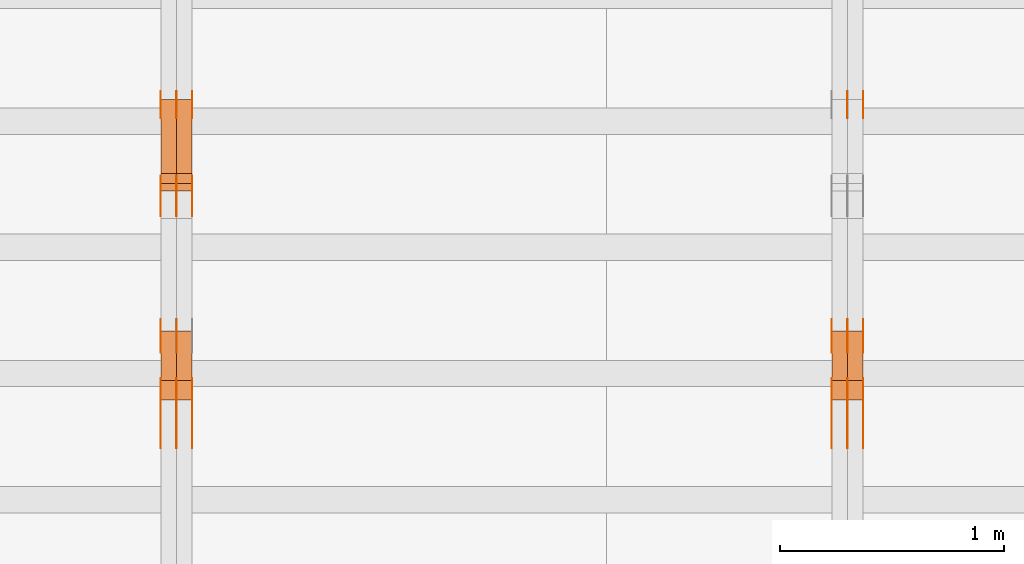
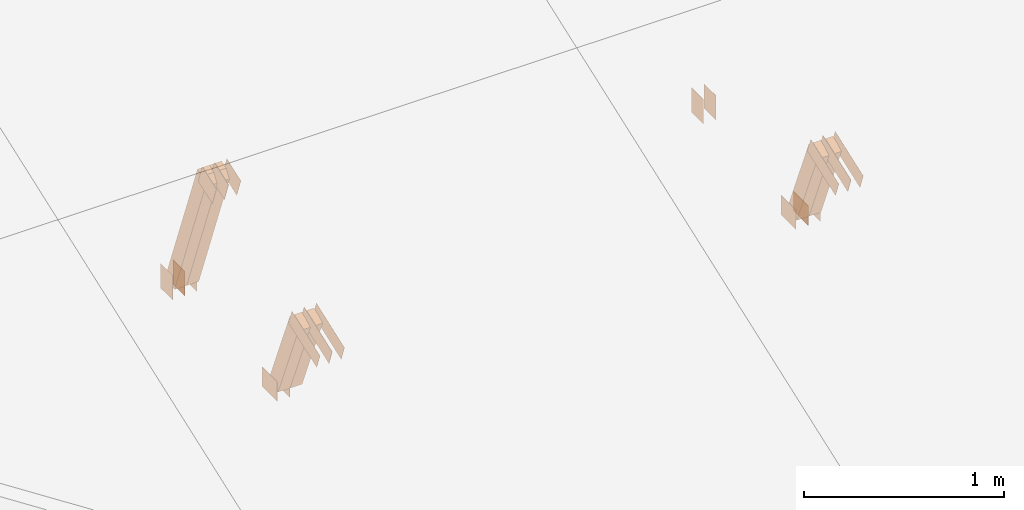
# One storey, part 140 of 189: 30 proxies.
"""IFC2X3 building model written with IfcOpenShell, lengths in millimetres."""

from ifc_helpers import new_model, entity, si_unit, converted_unit, derived_unit, direction, frame, frame_2d, origin, origin_2d_with_axis, place, context, subcontext, project, spatial, polyline, rectangle, outline, extrude, source, transform, mapped, material, type_object, type_shapes, element, save


model = new_model("IFC2X3")

# Units and contexts
model_context = context("Model", 3, precision=0.01, world=origin(), true_north=direction((6.12303176911189e-17, 1.0)))
body_context = subcontext(model_context, "Body", "Model", "MODEL_VIEW")
ifc_project = project(units=[si_unit("LENGTHUNIT", "METRE", prefix="MILLI"), si_unit("AREAUNIT", "SQUARE_METRE"), si_unit("VOLUMEUNIT", "CUBIC_METRE"), converted_unit("PLANEANGLEUNIT", "DEGREE", entity("IfcRatioMeasure", 0.0174532925199433), si_unit("PLANEANGLEUNIT", "RADIAN"), dimensions=[0, 0, 0, 0, 0, 0, 0]), si_unit("MASSUNIT", "GRAM", prefix="KILO"), derived_unit("MASSDENSITYUNIT", [(si_unit("MASSUNIT", "GRAM", prefix="KILO"), 1), (si_unit("LENGTHUNIT", "METRE"), -3)]), si_unit("TIMEUNIT", "SECOND"), si_unit("FREQUENCYUNIT", "HERTZ"), si_unit("THERMODYNAMICTEMPERATUREUNIT", "DEGREE_CELSIUS"), derived_unit("THERMALTRANSMITTANCEUNIT", [(si_unit("MASSUNIT", "GRAM", prefix="KILO"), 1), (si_unit("THERMODYNAMICTEMPERATUREUNIT", "KELVIN"), -1), (si_unit("TIMEUNIT", "SECOND"), -3)]), derived_unit("VOLUMETRICFLOWRATEUNIT", [(si_unit("LENGTHUNIT", "METRE"), 3), (si_unit("TIMEUNIT", "SECOND"), -1)]), si_unit("ELECTRICCURRENTUNIT", "AMPERE"), si_unit("ELECTRICVOLTAGEUNIT", "VOLT"), si_unit("POWERUNIT", "WATT"), si_unit("FORCEUNIT", "NEWTON"), si_unit("ILLUMINANCEUNIT", "LUX"), si_unit("LUMINOUSFLUXUNIT", "LUMEN"), si_unit("LUMINOUSINTENSITYUNIT", "CANDELA"), derived_unit("USERDEFINED", [(si_unit("MASSUNIT", "GRAM", prefix="KILO"), -1), (si_unit("LENGTHUNIT", "METRE"), -2), (si_unit("TIMEUNIT", "SECOND"), 3), (si_unit("LUMINOUSFLUXUNIT", "LUMEN"), 1)]), derived_unit("LINEARVELOCITYUNIT", [(si_unit("LENGTHUNIT", "METRE"), 1), (si_unit("TIMEUNIT", "SECOND"), -1)]), si_unit("PRESSUREUNIT", "PASCAL"), derived_unit("USERDEFINED", [(si_unit("LENGTHUNIT", "METRE"), -2), (si_unit("MASSUNIT", "GRAM", prefix="KILO"), 1), (si_unit("TIMEUNIT", "SECOND"), -2)])], contexts=[model_context])

# Site, building, storey
site_placement = place(None, origin())
site = spatial("IfcSite", under=ifc_project, at=site_placement, CompositionType="ELEMENT")
building_placement = place(site_placement, origin())
building = spatial("IfcBuilding", under=site, at=building_placement, CompositionType="ELEMENT")
storey_placement = place(building_placement, origin())
storey = spatial("IfcBuildingStorey", under=building, at=storey_placement, Name="Default", CompositionType="ELEMENT", Elevation=0.0)

# Proxies
ifc_material_1 = material(Name="IfcSurfaceStyle #231430")
building_element_proxy_type_1 = type_object("IfcBuildingElementProxyType", PredefinedType="NOTDEFINED", material=ifc_material_1)
shared_shape_1 = source(origin(), body_context, "Body", "SweptSolid", [
    extrude(rectangle(XDim=150.0, YDim=120.0, at=frame_2d((1.4210854715202e-14, -7.105427357601e-15), x_axis=(1.0, 0.0))), frame((75.0, 60.0004961323721, 0.0), z_axis=(0.0, 0.0, 1.0), x_axis=(-1.0, 0.0, 0.0)), (0.0, 0.0, 1.0), 1.3),
])
type_shapes(building_element_proxy_type_1, [shared_shape_1])
proxy_1_placement = place(building_placement, frame((42301.3, 2940.99169136763, 170.0), z_axis=(-1.0, 0.0, 0.0), x_axis=(0.0, 0.0, 1.0)))
element("IfcBuildingElementProxy", 1, at=proxy_1_placement, inside=storey, type_object=building_element_proxy_type_1, material=ifc_material_1, context=body_context, shape_type="MappedRepresentation", body=[
    mapped(shared_shape_1, transform((0.0, 0.0, 0.0), scale=1.0)),
])
ifc_material_2 = material(Name="IfcSurfaceStyle #231373")
building_element_proxy_type_2 = type_object("IfcBuildingElementProxyType", PredefinedType="NOTDEFINED", material=ifc_material_2)
shared_shape_2 = source(origin(), body_context, "Body", "SweptSolid", [
    extrude(rectangle(XDim=150.0, YDim=120.0, at=frame_2d((1.4210854715202e-14, -7.105427357601e-15), x_axis=(1.0, 0.0))), frame((75.0, 60.0004961323721, 0.0), z_axis=(0.0, 0.0, 1.0), x_axis=(-1.0, 0.0, 0.0)), (0.0, 0.0, 1.0), 1.29999999999999),
])
type_shapes(building_element_proxy_type_2, [shared_shape_2])
proxy_2_placement = place(building_placement, frame((42230.0, 2940.99169136763, 170.0), z_axis=(-1.0, 0.0, 0.0), x_axis=(0.0, 0.0, 1.0)))
element("IfcBuildingElementProxy", 2, at=proxy_2_placement, inside=storey, type_object=building_element_proxy_type_2, material=ifc_material_2, context=body_context, shape_type="MappedRepresentation", body=[
    mapped(shared_shape_2, transform((0.0, 0.0, 0.0), scale=1.0)),
])
ifc_material_3 = material(Name="IfcSurfaceStyle #230518")
building_element_proxy_type_3 = type_object("IfcBuildingElementProxyType", PredefinedType="NOTDEFINED", material=ifc_material_3)
shared_shape_3 = source(origin(), body_context, "Body", "SweptSolid", [
    extrude(rectangle(XDim=150.0, YDim=120.0, at=origin_2d_with_axis()), frame((75.0004757715869, 60.0, 0.0), z_axis=(0.0, 0.0, 1.0), x_axis=(-1.0, 0.0, 0.0)), (0.0, 0.0, 1.0), 1.3),
])
type_shapes(building_element_proxy_type_3, [shared_shape_3])
proxy_3_placement = place(building_placement, frame((42301.3, 1892.68702422841, 305.0), z_axis=(-1.0, 0.0, 0.0), x_axis=(0.0, 1.0, 0.0)))
element("IfcBuildingElementProxy", 3, at=proxy_3_placement, inside=storey, type_object=building_element_proxy_type_3, material=ifc_material_3, context=body_context, shape_type="MappedRepresentation", body=[
    mapped(shared_shape_3, transform((0.0, 0.0, 0.0), scale=1.0)),
])
ifc_material_4 = material(Name="IfcSurfaceStyle #230461")
building_element_proxy_type_4 = type_object("IfcBuildingElementProxyType", PredefinedType="NOTDEFINED", material=ifc_material_4)
shared_shape_4 = source(origin(), body_context, "Body", "SweptSolid", [
    extrude(rectangle(XDim=150.0, YDim=120.0, at=origin_2d_with_axis()), frame((75.0004757715869, 60.0, 0.0), z_axis=(0.0, 0.0, 1.0), x_axis=(-1.0, 0.0, 0.0)), (0.0, 0.0, 1.0), 1.29999999999999),
])
type_shapes(building_element_proxy_type_4, [shared_shape_4])
proxy_4_placement = place(building_placement, frame((42230.0, 1892.68702422841, 305.0), z_axis=(-1.0, 0.0, 0.0), x_axis=(0.0, 1.0, 0.0)))
element("IfcBuildingElementProxy", 4, at=proxy_4_placement, inside=storey, type_object=building_element_proxy_type_4, material=ifc_material_4, context=body_context, shape_type="MappedRepresentation", body=[
    mapped(shared_shape_4, transform((0.0, 0.0, 0.0), scale=1.0)),
])
ifc_material_5 = material(Name="IfcSurfaceStyle #230404")
building_element_proxy_type_5 = type_object("IfcBuildingElementProxyType", PredefinedType="NOTDEFINED", material=ifc_material_5)
shared_shape_5 = source(origin(), body_context, "Body", "SweptSolid", [
    extrude(rectangle(XDim=150.0, YDim=120.0, at=origin_2d_with_axis()), frame((75.0004757715869, 60.0, 0.0), z_axis=(0.0, 0.0, 1.0), x_axis=(-1.0, 0.0, 0.0)), (0.0, 0.0, 1.0), 1.29999999999999),
])
type_shapes(building_element_proxy_type_5, [shared_shape_5])
proxy_5_placement = place(building_placement, frame((42231.3, 1892.68702422841, 305.0), z_axis=(-1.0, 0.0, 0.0), x_axis=(0.0, 1.0, 0.0)))
element("IfcBuildingElementProxy", 5, at=proxy_5_placement, inside=storey, type_object=building_element_proxy_type_5, material=ifc_material_5, context=body_context, shape_type="MappedRepresentation", body=[
    mapped(shared_shape_5, transform((0.0, 0.0, 0.0), scale=1.0)),
])
ifc_material_6 = material(Name="IfcSurfaceStyle #230347")
building_element_proxy_type_6 = type_object("IfcBuildingElementProxyType", PredefinedType="NOTDEFINED", material=ifc_material_6)
shared_shape_6 = source(origin(), body_context, "Body", "SweptSolid", [
    extrude(rectangle(XDim=150.0, YDim=120.0, at=origin_2d_with_axis()), frame((75.0004757715869, 60.0, 0.0), z_axis=(0.0, 0.0, 1.0), x_axis=(-1.0, 0.0, 0.0)), (0.0, 0.0, 1.0), 1.29999999999999),
])
type_shapes(building_element_proxy_type_6, [shared_shape_6])
proxy_6_placement = place(building_placement, frame((42160.0, 1892.68702422841, 305.0), z_axis=(-1.0, 0.0, 0.0), x_axis=(0.0, 1.0, 0.0)))
element("IfcBuildingElementProxy", 6, at=proxy_6_placement, inside=storey, type_object=building_element_proxy_type_6, material=ifc_material_6, context=body_context, shape_type="MappedRepresentation", body=[
    mapped(shared_shape_6, transform((0.0, 0.0, 0.0), scale=1.0)),
])
ifc_material_7 = material(Name="IfcSurfaceStyle #230290")
building_element_proxy_type_7 = type_object("IfcBuildingElementProxyType", PredefinedType="NOTDEFINED", material=ifc_material_7)
shared_shape_7 = source(origin(), body_context, "Body", "SweptSolid", [
    extrude(outline(polyline([(-150.000217420008, -47.9999344162752), (150.000165800718, -47.9999344162752), (150.000227857633, 47.9999344162752), (-150.000176238343, 47.9999344162752), (-150.000217420008, -47.9999344162752)])), frame((150.000227857633, 48.0000430742566, 0.0), z_axis=(0.0, 0.0, 1.0), x_axis=(-1.0, 0.0, 0.0)), (0.0, 0.0, 1.0), 1.29999999999999),
])
type_shapes(building_element_proxy_type_7, [shared_shape_7])
proxy_7_placement = place(building_placement, frame((42301.3, 1464.46484375, 723.378723144533), z_axis=(-1.0, 0.0, 0.0), x_axis=(0.0, 0.939692620785908, 0.342020143325669)))
element("IfcBuildingElementProxy", 7, at=proxy_7_placement, inside=storey, type_object=building_element_proxy_type_7, material=ifc_material_7, context=body_context, shape_type="MappedRepresentation", body=[
    mapped(shared_shape_7, transform((0.0, 0.0, 0.0), scale=1.0)),
])
ifc_material_8 = material(Name="IfcSurfaceStyle #230233")
building_element_proxy_type_8 = type_object("IfcBuildingElementProxyType", PredefinedType="NOTDEFINED", material=ifc_material_8)
shared_shape_8 = source(origin(), body_context, "Body", "SweptSolid", [
    extrude(outline(polyline([(-150.000217420008, -47.9999344162752), (150.000165800718, -47.9999344162752), (150.000227857633, 47.9999344162752), (-150.000176238343, 47.9999344162752), (-150.000217420008, -47.9999344162752)])), frame((150.000227857633, 48.0000430742566, 0.0), z_axis=(0.0, 0.0, 1.0), x_axis=(-1.0, 0.0, 0.0)), (0.0, 0.0, 1.0), 1.29999999999998),
])
type_shapes(building_element_proxy_type_8, [shared_shape_8])
proxy_8_placement = place(building_placement, frame((42230.0, 1464.46484375, 723.378723144533), z_axis=(-1.0, 0.0, 0.0), x_axis=(0.0, 0.939692620785908, 0.342020143325669)))
element("IfcBuildingElementProxy", 8, at=proxy_8_placement, inside=storey, type_object=building_element_proxy_type_8, material=ifc_material_8, context=body_context, shape_type="MappedRepresentation", body=[
    mapped(shared_shape_8, transform((0.0, 0.0, 0.0), scale=1.0)),
])
ifc_material_9 = material(Name="IfcSurfaceStyle #230176")
building_element_proxy_type_9 = type_object("IfcBuildingElementProxyType", PredefinedType="NOTDEFINED", material=ifc_material_9)
shared_shape_9 = source(origin(), body_context, "Body", "SweptSolid", [
    extrude(outline(polyline([(-150.000217420008, -47.9999344162752), (150.000165800718, -47.9999344162752), (150.000227857633, 47.9999344162752), (-150.000176238343, 47.9999344162752), (-150.000217420008, -47.9999344162752)])), frame((150.000227857633, 48.0000430742566, 0.0), z_axis=(0.0, 0.0, 1.0), x_axis=(-1.0, 0.0, 0.0)), (0.0, 0.0, 1.0), 1.29999999999998),
])
type_shapes(building_element_proxy_type_9, [shared_shape_9])
proxy_9_placement = place(building_placement, frame((42231.3, 1464.46484375, 723.378723144533), z_axis=(-1.0, 0.0, 0.0), x_axis=(0.0, 0.939692620785908, 0.342020143325669)))
element("IfcBuildingElementProxy", 9, at=proxy_9_placement, inside=storey, type_object=building_element_proxy_type_9, material=ifc_material_9, context=body_context, shape_type="MappedRepresentation", body=[
    mapped(shared_shape_9, transform((0.0, 0.0, 0.0), scale=1.0)),
])
ifc_material_10 = material(Name="IfcSurfaceStyle #230119")
building_element_proxy_type_10 = type_object("IfcBuildingElementProxyType", PredefinedType="NOTDEFINED", material=ifc_material_10)
shared_shape_10 = source(origin(), body_context, "Body", "SweptSolid", [
    extrude(outline(polyline([(-150.000217420008, -47.9999344162752), (150.000165800718, -47.9999344162752), (150.000227857633, 47.9999344162752), (-150.000176238343, 47.9999344162752), (-150.000217420008, -47.9999344162752)])), frame((150.000227857633, 48.0000430742566, 0.0), z_axis=(0.0, 0.0, 1.0), x_axis=(-1.0, 0.0, 0.0)), (0.0, 0.0, 1.0), 1.29999999999998),
])
type_shapes(building_element_proxy_type_10, [shared_shape_10])
proxy_10_placement = place(building_placement, frame((42160.0, 1464.46484375, 723.378723144533), z_axis=(-1.0, 0.0, 0.0), x_axis=(0.0, 0.939692620785908, 0.342020143325669)))
element("IfcBuildingElementProxy", 10, at=proxy_10_placement, inside=storey, type_object=building_element_proxy_type_10, material=ifc_material_10, context=body_context, shape_type="MappedRepresentation", body=[
    mapped(shared_shape_10, transform((0.0, 0.0, 0.0), scale=1.0)),
])
ifc_material_11 = material(Name="IfcSurfaceStyle #223102")
building_element_proxy_type_11 = type_object("IfcBuildingElementProxyType", Name="T1-W15 223100", PredefinedType="NOTDEFINED", material=ifc_material_11)
shared_shape_11 = source(origin(), body_context, "Body", "SweptSolid", [
    extrude(outline(polyline([(-317.132720418368, -47.5005147440206), (220.445242566881, -47.5005147440206), (227.5021778825, -0.000126286009697951), (225.500088907744, 47.5005778870255), (-356.314788938758, 47.5005778870255), (-317.132720418368, -47.5005147440206)])), frame((227.5021778825, 47.5005778870255, 0.0), z_axis=(0.0, 0.0, 1.0), x_axis=(-1.0, 0.0, 0.0)), (0.0, 0.0, 1.0), 70.0),
])
type_shapes(building_element_proxy_type_11, [shared_shape_11])
proxy_11_placement = place(building_placement, frame((42300.0, 1767.47882447529, 784.714556181707), z_axis=(-1.0, 0.0, 0.0), x_axis=(0.0, 0.381283266795389, -0.924458257825542)))
element("IfcBuildingElementProxy", 11, at=proxy_11_placement, inside=storey, type_object=building_element_proxy_type_11, material=ifc_material_11, Name="T1-W15", context=body_context, shape_type="MappedRepresentation", body=[
    mapped(shared_shape_11, transform((0.0, 0.0, 0.0), scale=1.0)),
])
ifc_material_12 = material(Name="IfcSurfaceStyle #223036")
building_element_proxy_type_12 = type_object("IfcBuildingElementProxyType", Name="T1-W15 223034", PredefinedType="NOTDEFINED", material=ifc_material_12)
shared_shape_12 = source(origin(), body_context, "Body", "SweptSolid", [
    extrude(outline(polyline([(-317.132720418368, -47.5005147440206), (220.445242566881, -47.5005147440206), (227.5021778825, -0.000126286009697951), (225.500088907744, 47.5005778870255), (-356.314788938758, 47.5005778870255), (-317.132720418368, -47.5005147440206)])), frame((227.5021778825, 47.5005778870255, 0.0), z_axis=(0.0, 0.0, 1.0), x_axis=(-1.0, 0.0, 0.0)), (0.0, 0.0, 1.0), 70.0),
])
type_shapes(building_element_proxy_type_12, [shared_shape_12])
proxy_12_placement = place(building_placement, frame((42230.0, 1767.47882447529, 784.714556181707), z_axis=(-1.0, 0.0, 0.0), x_axis=(0.0, 0.381283266795389, -0.924458257825542)))
element("IfcBuildingElementProxy", 12, at=proxy_12_placement, inside=storey, type_object=building_element_proxy_type_12, material=ifc_material_12, Name="T1-W15", context=body_context, shape_type="MappedRepresentation", body=[
    mapped(shared_shape_12, transform((0.0, 0.0, 0.0), scale=1.0)),
])
ifc_material_13 = material(Name="IfcSurfaceStyle #215640")
building_element_proxy_type_13 = type_object("IfcBuildingElementProxyType", PredefinedType="NOTDEFINED", material=ifc_material_13)
shared_shape_13 = source(origin(), body_context, "Body", "SweptSolid", [
    extrude(rectangle(XDim=150.0, YDim=120.0, at=frame_2d((1.4210854715202e-14, -7.105427357601e-15), x_axis=(1.0, 0.0))), frame((75.0, 60.0004961323721, 0.0), z_axis=(0.0, 0.0, 1.0), x_axis=(-1.0, 0.0, 0.0)), (0.0, 0.0, 1.0), 1.3),
])
type_shapes(building_element_proxy_type_13, [shared_shape_13])
proxy_13_placement = place(building_placement, frame((39301.3, 2940.99169136763, 170.0), z_axis=(-1.0, 0.0, 0.0), x_axis=(0.0, 0.0, 1.0)))
element("IfcBuildingElementProxy", 13, at=proxy_13_placement, inside=storey, type_object=building_element_proxy_type_13, material=ifc_material_13, context=body_context, shape_type="MappedRepresentation", body=[
    mapped(shared_shape_13, transform((0.0, 0.0, 0.0), scale=1.0)),
])
ifc_material_14 = material(Name="IfcSurfaceStyle #215583")
building_element_proxy_type_14 = type_object("IfcBuildingElementProxyType", PredefinedType="NOTDEFINED", material=ifc_material_14)
shared_shape_14 = source(origin(), body_context, "Body", "SweptSolid", [
    extrude(rectangle(XDim=150.0, YDim=120.0, at=frame_2d((1.4210854715202e-14, -7.105427357601e-15), x_axis=(1.0, 0.0))), frame((75.0, 60.0004961323721, 0.0), z_axis=(0.0, 0.0, 1.0), x_axis=(-1.0, 0.0, 0.0)), (0.0, 0.0, 1.0), 1.29999999999999),
])
type_shapes(building_element_proxy_type_14, [shared_shape_14])
proxy_14_placement = place(building_placement, frame((39230.0, 2940.99169136763, 170.0), z_axis=(-1.0, 0.0, 0.0), x_axis=(0.0, 0.0, 1.0)))
element("IfcBuildingElementProxy", 14, at=proxy_14_placement, inside=storey, type_object=building_element_proxy_type_14, material=ifc_material_14, context=body_context, shape_type="MappedRepresentation", body=[
    mapped(shared_shape_14, transform((0.0, 0.0, 0.0), scale=1.0)),
])
ifc_material_15 = material(Name="IfcSurfaceStyle #215526")
building_element_proxy_type_15 = type_object("IfcBuildingElementProxyType", PredefinedType="NOTDEFINED", material=ifc_material_15)
shared_shape_15 = source(origin(), body_context, "Body", "SweptSolid", [
    extrude(rectangle(XDim=150.0, YDim=120.0, at=frame_2d((1.4210854715202e-14, -7.105427357601e-15), x_axis=(1.0, 0.0))), frame((75.0, 60.0004961323721, 0.0), z_axis=(0.0, 0.0, 1.0), x_axis=(-1.0, 0.0, 0.0)), (0.0, 0.0, 1.0), 1.29999999999999),
])
type_shapes(building_element_proxy_type_15, [shared_shape_15])
proxy_15_placement = place(building_placement, frame((39231.3, 2940.99169136763, 170.0), z_axis=(-1.0, 0.0, 0.0), x_axis=(0.0, 0.0, 1.0)))
element("IfcBuildingElementProxy", 15, at=proxy_15_placement, inside=storey, type_object=building_element_proxy_type_15, material=ifc_material_15, context=body_context, shape_type="MappedRepresentation", body=[
    mapped(shared_shape_15, transform((0.0, 0.0, 0.0), scale=1.0)),
])
ifc_material_16 = material(Name="IfcSurfaceStyle #215469")
building_element_proxy_type_16 = type_object("IfcBuildingElementProxyType", PredefinedType="NOTDEFINED", material=ifc_material_16)
shared_shape_16 = source(origin(), body_context, "Body", "SweptSolid", [
    extrude(rectangle(XDim=150.0, YDim=120.0, at=frame_2d((1.4210854715202e-14, -7.105427357601e-15), x_axis=(1.0, 0.0))), frame((75.0, 60.0004961323721, 0.0), z_axis=(0.0, 0.0, 1.0), x_axis=(-1.0, 0.0, 0.0)), (0.0, 0.0, 1.0), 1.29999999999999),
])
type_shapes(building_element_proxy_type_16, [shared_shape_16])
proxy_16_placement = place(building_placement, frame((39160.0, 2940.99169136763, 170.0), z_axis=(-1.0, 0.0, 0.0), x_axis=(0.0, 0.0, 1.0)))
element("IfcBuildingElementProxy", 16, at=proxy_16_placement, inside=storey, type_object=building_element_proxy_type_16, material=ifc_material_16, context=body_context, shape_type="MappedRepresentation", body=[
    mapped(shared_shape_16, transform((0.0, 0.0, 0.0), scale=1.0)),
])
ifc_material_17 = material(Name="IfcSurfaceStyle #215412")
building_element_proxy_type_17 = type_object("IfcBuildingElementProxyType", PredefinedType="NOTDEFINED", material=ifc_material_17)
shared_shape_17 = source(origin(), body_context, "Body", "SweptSolid", [
    extrude(outline(polyline([(-75.0008071857483, -59.9999039432187), (75.0002916555677, -59.9999039432187), (75.0008280609982, 59.9999039432187), (-75.0003125308176, 59.9999039432187), (-75.0008071857483, -59.9999039432187)])), frame((75.0008280609982, 60.0002349219685, 0.0), z_axis=(0.0, 0.0, 1.0), x_axis=(-1.0, 0.0, 0.0)), (0.0, 0.0, 1.0), 1.3),
])
type_shapes(building_element_proxy_type_17, [shared_shape_17])
proxy_17_placement = place(building_placement, frame((39301.3, 2502.466796875, 1113.95080566406), z_axis=(-1.0, 0.0, 0.0), x_axis=(0.0, 0.939692620785908, 0.342020143325669)))
element("IfcBuildingElementProxy", 17, at=proxy_17_placement, inside=storey, type_object=building_element_proxy_type_17, material=ifc_material_17, context=body_context, shape_type="MappedRepresentation", body=[
    mapped(shared_shape_17, transform((0.0, 0.0, 0.0), scale=1.0)),
])
ifc_material_18 = material(Name="IfcSurfaceStyle #215355")
building_element_proxy_type_18 = type_object("IfcBuildingElementProxyType", PredefinedType="NOTDEFINED", material=ifc_material_18)
shared_shape_18 = source(origin(), body_context, "Body", "SweptSolid", [
    extrude(outline(polyline([(-75.0008071857483, -59.9999039432187), (75.0002916555677, -59.9999039432187), (75.0008280609982, 59.9999039432187), (-75.0003125308176, 59.9999039432187), (-75.0008071857483, -59.9999039432187)])), frame((75.0008280609982, 60.0002349219685, 0.0), z_axis=(0.0, 0.0, 1.0), x_axis=(-1.0, 0.0, 0.0)), (0.0, 0.0, 1.0), 1.29999999999999),
])
type_shapes(building_element_proxy_type_18, [shared_shape_18])
proxy_18_placement = place(building_placement, frame((39230.0, 2502.466796875, 1113.95080566406), z_axis=(-1.0, 0.0, 0.0), x_axis=(0.0, 0.939692620785908, 0.342020143325669)))
element("IfcBuildingElementProxy", 18, at=proxy_18_placement, inside=storey, type_object=building_element_proxy_type_18, material=ifc_material_18, context=body_context, shape_type="MappedRepresentation", body=[
    mapped(shared_shape_18, transform((0.0, 0.0, 0.0), scale=1.0)),
])
ifc_material_19 = material(Name="IfcSurfaceStyle #215298")
building_element_proxy_type_19 = type_object("IfcBuildingElementProxyType", PredefinedType="NOTDEFINED", material=ifc_material_19)
shared_shape_19 = source(origin(), body_context, "Body", "SweptSolid", [
    extrude(outline(polyline([(-75.0008071857483, -59.9999039432187), (75.0002916555677, -59.9999039432187), (75.0008280609982, 59.9999039432187), (-75.0003125308176, 59.9999039432187), (-75.0008071857483, -59.9999039432187)])), frame((75.0008280609982, 60.0002349219685, 0.0), z_axis=(0.0, 0.0, 1.0), x_axis=(-1.0, 0.0, 0.0)), (0.0, 0.0, 1.0), 1.29999999999999),
])
type_shapes(building_element_proxy_type_19, [shared_shape_19])
proxy_19_placement = place(building_placement, frame((39231.3, 2502.466796875, 1113.95080566406), z_axis=(-1.0, 0.0, 0.0), x_axis=(0.0, 0.939692620785908, 0.342020143325669)))
element("IfcBuildingElementProxy", 19, at=proxy_19_placement, inside=storey, type_object=building_element_proxy_type_19, material=ifc_material_19, context=body_context, shape_type="MappedRepresentation", body=[
    mapped(shared_shape_19, transform((0.0, 0.0, 0.0), scale=1.0)),
])
ifc_material_20 = material(Name="IfcSurfaceStyle #215241")
building_element_proxy_type_20 = type_object("IfcBuildingElementProxyType", PredefinedType="NOTDEFINED", material=ifc_material_20)
shared_shape_20 = source(origin(), body_context, "Body", "SweptSolid", [
    extrude(outline(polyline([(-75.0008071857483, -59.9999039432187), (75.0002916555677, -59.9999039432187), (75.0008280609982, 59.9999039432187), (-75.0003125308176, 59.9999039432187), (-75.0008071857483, -59.9999039432187)])), frame((75.0008280609982, 60.0002349219685, 0.0), z_axis=(0.0, 0.0, 1.0), x_axis=(-1.0, 0.0, 0.0)), (0.0, 0.0, 1.0), 1.29999999999999),
])
type_shapes(building_element_proxy_type_20, [shared_shape_20])
proxy_20_placement = place(building_placement, frame((39160.0, 2502.466796875, 1113.95080566406), z_axis=(-1.0, 0.0, 0.0), x_axis=(0.0, 0.939692620785908, 0.342020143325669)))
element("IfcBuildingElementProxy", 20, at=proxy_20_placement, inside=storey, type_object=building_element_proxy_type_20, material=ifc_material_20, context=body_context, shape_type="MappedRepresentation", body=[
    mapped(shared_shape_20, transform((0.0, 0.0, 0.0), scale=1.0)),
])
ifc_material_21 = material(Name="IfcSurfaceStyle #214614")
building_element_proxy_type_21 = type_object("IfcBuildingElementProxyType", PredefinedType="NOTDEFINED", material=ifc_material_21)
shared_shape_21 = source(origin(), body_context, "Body", "SweptSolid", [
    extrude(rectangle(XDim=150.0, YDim=120.0, at=origin_2d_with_axis()), frame((75.0004757715869, 60.0, 0.0), z_axis=(0.0, 0.0, 1.0), x_axis=(-1.0, 0.0, 0.0)), (0.0, 0.0, 1.0), 1.29999999999999),
])
type_shapes(building_element_proxy_type_21, [shared_shape_21])
proxy_21_placement = place(building_placement, frame((39231.3, 1892.68702422841, 305.0), z_axis=(-1.0, 0.0, 0.0), x_axis=(0.0, 1.0, 0.0)))
element("IfcBuildingElementProxy", 21, at=proxy_21_placement, inside=storey, type_object=building_element_proxy_type_21, material=ifc_material_21, context=body_context, shape_type="MappedRepresentation", body=[
    mapped(shared_shape_21, transform((0.0, 0.0, 0.0), scale=1.0)),
])
ifc_material_22 = material(Name="IfcSurfaceStyle #214557")
building_element_proxy_type_22 = type_object("IfcBuildingElementProxyType", PredefinedType="NOTDEFINED", material=ifc_material_22)
shared_shape_22 = source(origin(), body_context, "Body", "SweptSolid", [
    extrude(rectangle(XDim=150.0, YDim=120.0, at=origin_2d_with_axis()), frame((75.0004757715869, 60.0, 0.0), z_axis=(0.0, 0.0, 1.0), x_axis=(-1.0, 0.0, 0.0)), (0.0, 0.0, 1.0), 1.29999999999999),
])
type_shapes(building_element_proxy_type_22, [shared_shape_22])
proxy_22_placement = place(building_placement, frame((39160.0, 1892.68702422841, 305.0), z_axis=(-1.0, 0.0, 0.0), x_axis=(0.0, 1.0, 0.0)))
element("IfcBuildingElementProxy", 22, at=proxy_22_placement, inside=storey, type_object=building_element_proxy_type_22, material=ifc_material_22, context=body_context, shape_type="MappedRepresentation", body=[
    mapped(shared_shape_22, transform((0.0, 0.0, 0.0), scale=1.0)),
])
ifc_material_23 = material(Name="IfcSurfaceStyle #214500")
building_element_proxy_type_23 = type_object("IfcBuildingElementProxyType", PredefinedType="NOTDEFINED", material=ifc_material_23)
shared_shape_23 = source(origin(), body_context, "Body", "SweptSolid", [
    extrude(outline(polyline([(-150.000217420008, -47.9999344162752), (150.000165800718, -47.9999344162752), (150.000227857633, 47.9999344162752), (-150.000176238343, 47.9999344162752), (-150.000217420008, -47.9999344162752)])), frame((150.000227857633, 48.0000430742566, 0.0), z_axis=(0.0, 0.0, 1.0), x_axis=(-1.0, 0.0, 0.0)), (0.0, 0.0, 1.0), 1.29999999999999),
])
type_shapes(building_element_proxy_type_23, [shared_shape_23])
proxy_23_placement = place(building_placement, frame((39301.3, 1464.46484375, 723.378723144533), z_axis=(-1.0, 0.0, 0.0), x_axis=(0.0, 0.939692620785908, 0.342020143325669)))
element("IfcBuildingElementProxy", 23, at=proxy_23_placement, inside=storey, type_object=building_element_proxy_type_23, material=ifc_material_23, context=body_context, shape_type="MappedRepresentation", body=[
    mapped(shared_shape_23, transform((0.0, 0.0, 0.0), scale=1.0)),
])
ifc_material_24 = material(Name="IfcSurfaceStyle #214443")
building_element_proxy_type_24 = type_object("IfcBuildingElementProxyType", PredefinedType="NOTDEFINED", material=ifc_material_24)
shared_shape_24 = source(origin(), body_context, "Body", "SweptSolid", [
    extrude(outline(polyline([(-150.000217420008, -47.9999344162752), (150.000165800718, -47.9999344162752), (150.000227857633, 47.9999344162752), (-150.000176238343, 47.9999344162752), (-150.000217420008, -47.9999344162752)])), frame((150.000227857633, 48.0000430742566, 0.0), z_axis=(0.0, 0.0, 1.0), x_axis=(-1.0, 0.0, 0.0)), (0.0, 0.0, 1.0), 1.29999999999998),
])
type_shapes(building_element_proxy_type_24, [shared_shape_24])
proxy_24_placement = place(building_placement, frame((39230.0, 1464.46484375, 723.378723144533), z_axis=(-1.0, 0.0, 0.0), x_axis=(0.0, 0.939692620785908, 0.342020143325669)))
element("IfcBuildingElementProxy", 24, at=proxy_24_placement, inside=storey, type_object=building_element_proxy_type_24, material=ifc_material_24, context=body_context, shape_type="MappedRepresentation", body=[
    mapped(shared_shape_24, transform((0.0, 0.0, 0.0), scale=1.0)),
])
ifc_material_25 = material(Name="IfcSurfaceStyle #214386")
building_element_proxy_type_25 = type_object("IfcBuildingElementProxyType", PredefinedType="NOTDEFINED", material=ifc_material_25)
shared_shape_25 = source(origin(), body_context, "Body", "SweptSolid", [
    extrude(outline(polyline([(-150.000217420008, -47.9999344162752), (150.000165800718, -47.9999344162752), (150.000227857633, 47.9999344162752), (-150.000176238343, 47.9999344162752), (-150.000217420008, -47.9999344162752)])), frame((150.000227857633, 48.0000430742566, 0.0), z_axis=(0.0, 0.0, 1.0), x_axis=(-1.0, 0.0, 0.0)), (0.0, 0.0, 1.0), 1.29999999999998),
])
type_shapes(building_element_proxy_type_25, [shared_shape_25])
proxy_25_placement = place(building_placement, frame((39231.3, 1464.46484375, 723.378723144533), z_axis=(-1.0, 0.0, 0.0), x_axis=(0.0, 0.939692620785908, 0.342020143325669)))
element("IfcBuildingElementProxy", 25, at=proxy_25_placement, inside=storey, type_object=building_element_proxy_type_25, material=ifc_material_25, context=body_context, shape_type="MappedRepresentation", body=[
    mapped(shared_shape_25, transform((0.0, 0.0, 0.0), scale=1.0)),
])
ifc_material_26 = material(Name="IfcSurfaceStyle #214329")
building_element_proxy_type_26 = type_object("IfcBuildingElementProxyType", PredefinedType="NOTDEFINED", material=ifc_material_26)
shared_shape_26 = source(origin(), body_context, "Body", "SweptSolid", [
    extrude(outline(polyline([(-150.000217420008, -47.9999344162752), (150.000165800718, -47.9999344162752), (150.000227857633, 47.9999344162752), (-150.000176238343, 47.9999344162752), (-150.000217420008, -47.9999344162752)])), frame((150.000227857633, 48.0000430742566, 0.0), z_axis=(0.0, 0.0, 1.0), x_axis=(-1.0, 0.0, 0.0)), (0.0, 0.0, 1.0), 1.29999999999998),
])
type_shapes(building_element_proxy_type_26, [shared_shape_26])
proxy_26_placement = place(building_placement, frame((39160.0, 1464.46484375, 723.378723144533), z_axis=(-1.0, 0.0, 0.0), x_axis=(0.0, 0.939692620785908, 0.342020143325669)))
element("IfcBuildingElementProxy", 26, at=proxy_26_placement, inside=storey, type_object=building_element_proxy_type_26, material=ifc_material_26, context=body_context, shape_type="MappedRepresentation", body=[
    mapped(shared_shape_26, transform((0.0, 0.0, 0.0), scale=1.0)),
])
ifc_material_27 = material(Name="IfcSurfaceStyle #207840")
building_element_proxy_type_27 = type_object("IfcBuildingElementProxyType", Name="T1-W14 207838", PredefinedType="NOTDEFINED", material=ifc_material_27)
shared_shape_27 = source(origin(), body_context, "Body", "SweptSolid", [
    extrude(outline(polyline([(-526.068269984593, -47.5004595774917), (341.27769108205, -47.5004595774917), (373.679499344758, 0.000392511719837607), (373.092506900368, 47.5002633216318), (-561.981427342584, 47.5002633216318), (-526.068269984593, -47.5004595774917)])), frame((373.67978783425, 47.5005221796964, 0.0), z_axis=(0.0, 0.0, 1.0), x_axis=(-1.0, 0.0, 0.0)), (0.0, 0.0, 1.0), 69.9999999999999),
])
type_shapes(building_element_proxy_type_27, [shared_shape_27])
proxy_27_placement = place(building_placement, frame((39300.0, 2693.38241954499, 1120.21215048788), z_axis=(-1.0, 0.0, 0.0), x_axis=(0.0, 0.353606472447916, -0.935394281916958)))
element("IfcBuildingElementProxy", 27, at=proxy_27_placement, inside=storey, type_object=building_element_proxy_type_27, material=ifc_material_27, Name="T1-W14", context=body_context, shape_type="MappedRepresentation", body=[
    mapped(shared_shape_27, transform((0.0, 0.0, 0.0), scale=1.0)),
])
ifc_material_28 = material(Name="IfcSurfaceStyle #207774")
building_element_proxy_type_28 = type_object("IfcBuildingElementProxyType", Name="T1-W14 207772", PredefinedType="NOTDEFINED", material=ifc_material_28)
shared_shape_28 = source(origin(), body_context, "Body", "SweptSolid", [
    extrude(outline(polyline([(-526.068269984593, -47.5004595774917), (341.27769108205, -47.5004595774917), (373.679499344758, 0.000392511719837607), (373.092506900368, 47.5002633216318), (-561.981427342584, 47.5002633216318), (-526.068269984593, -47.5004595774917)])), frame((373.67978783425, 47.5005221796964, 0.0), z_axis=(0.0, 0.0, 1.0), x_axis=(-1.0, 0.0, 0.0)), (0.0, 0.0, 1.0), 69.9999999999999),
])
type_shapes(building_element_proxy_type_28, [shared_shape_28])
proxy_28_placement = place(building_placement, frame((39230.0, 2693.38241954499, 1120.21215048788), z_axis=(-1.0, 0.0, 0.0), x_axis=(0.0, 0.353606472447916, -0.935394281916958)))
element("IfcBuildingElementProxy", 28, at=proxy_28_placement, inside=storey, type_object=building_element_proxy_type_28, material=ifc_material_28, Name="T1-W14", context=body_context, shape_type="MappedRepresentation", body=[
    mapped(shared_shape_28, transform((0.0, 0.0, 0.0), scale=1.0)),
])
ifc_material_29 = material(Name="IfcSurfaceStyle #207312")
building_element_proxy_type_29 = type_object("IfcBuildingElementProxyType", Name="T1-W15 207310", PredefinedType="NOTDEFINED", material=ifc_material_29)
shared_shape_29 = source(origin(), body_context, "Body", "SweptSolid", [
    extrude(outline(polyline([(-317.132720418368, -47.5005147440206), (220.445242566881, -47.5005147440206), (227.5021778825, -0.000126286009697951), (225.500088907744, 47.5005778870255), (-356.314788938758, 47.5005778870255), (-317.132720418368, -47.5005147440206)])), frame((227.5021778825, 47.5005778870255, 0.0), z_axis=(0.0, 0.0, 1.0), x_axis=(-1.0, 0.0, 0.0)), (0.0, 0.0, 1.0), 70.0),
])
type_shapes(building_element_proxy_type_29, [shared_shape_29])
proxy_29_placement = place(building_placement, frame((39300.0, 1767.47882447529, 784.714556181707), z_axis=(-1.0, 0.0, 0.0), x_axis=(0.0, 0.381283266795389, -0.924458257825542)))
element("IfcBuildingElementProxy", 29, at=proxy_29_placement, inside=storey, type_object=building_element_proxy_type_29, material=ifc_material_29, Name="T1-W15", context=body_context, shape_type="MappedRepresentation", body=[
    mapped(shared_shape_29, transform((0.0, 0.0, 0.0), scale=1.0)),
])
ifc_material_30 = material(Name="IfcSurfaceStyle #207246")
building_element_proxy_type_30 = type_object("IfcBuildingElementProxyType", Name="T1-W15 207244", PredefinedType="NOTDEFINED", material=ifc_material_30)
shared_shape_30 = source(origin(), body_context, "Body", "SweptSolid", [
    extrude(outline(polyline([(-317.132720418368, -47.5005147440206), (220.445242566881, -47.5005147440206), (227.5021778825, -0.000126286009697951), (225.500088907744, 47.5005778870255), (-356.314788938758, 47.5005778870255), (-317.132720418368, -47.5005147440206)])), frame((227.5021778825, 47.5005778870255, 0.0), z_axis=(0.0, 0.0, 1.0), x_axis=(-1.0, 0.0, 0.0)), (0.0, 0.0, 1.0), 70.0),
])
type_shapes(building_element_proxy_type_30, [shared_shape_30])
proxy_30_placement = place(building_placement, frame((39230.0, 1767.47882447529, 784.714556181707), z_axis=(-1.0, 0.0, 0.0), x_axis=(0.0, 0.381283266795389, -0.924458257825542)))
element("IfcBuildingElementProxy", 30, at=proxy_30_placement, inside=storey, type_object=building_element_proxy_type_30, material=ifc_material_30, Name="T1-W15", context=body_context, shape_type="MappedRepresentation", body=[
    mapped(shared_shape_30, transform((0.0, 0.0, 0.0), scale=1.0)),
])

save(model, "model.ifc")
